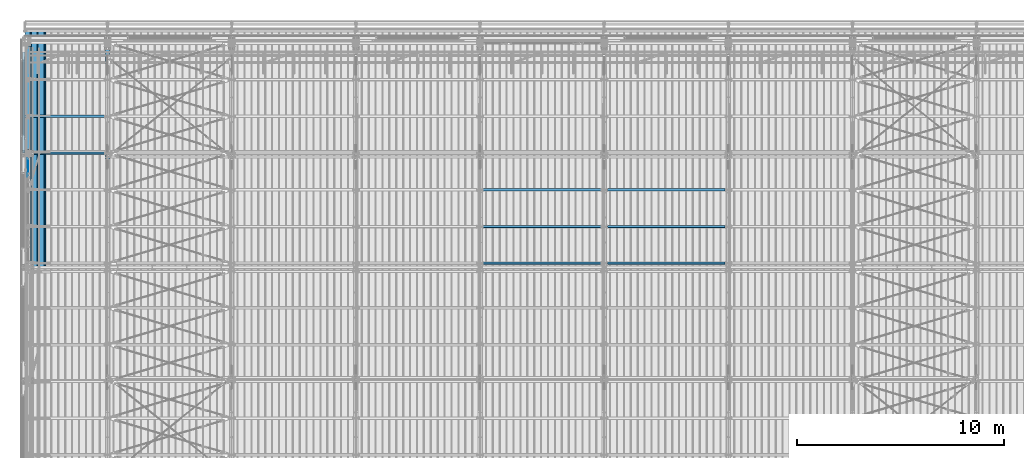
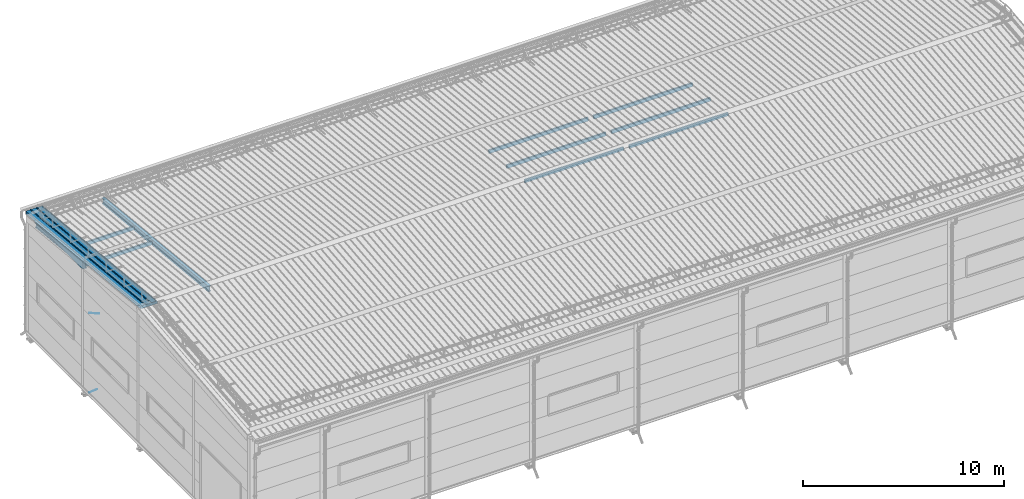
# One storey, part 262 of 709: 12 beams, 2 members, 2 openings, 14 elements without a shape of their own.
"""IFC4 building model written with IfcOpenShell, lengths in millimetres."""

from ifc_helpers import new_model, si_unit, direction, frame, origin_with_axes, place, context, subcontext, project, spatial, line, indexed_curve, outline, extrude, polygons, material, element, aggregate, save


model = new_model("IFC4")

# Units and contexts
model_context = context("Model", 3, precision=0.2, world=origin_with_axes(), true_north=direction((0.0, 1.0)))
body_context = subcontext(model_context, "Body", "Model", "MODEL_VIEW")
reference_context = subcontext(model_context, "Reference", "Model", "MODEL_VIEW")
ifc_project = project(units=[si_unit("LENGTHUNIT", "METRE", prefix="MILLI"), si_unit("AREAUNIT", "SQUARE_METRE"), si_unit("VOLUMEUNIT", "CUBIC_METRE"), si_unit("MASSUNIT", "GRAM", prefix="KILO"), si_unit("TIMEUNIT", "SECOND"), si_unit("PLANEANGLEUNIT", "RADIAN"), si_unit("SOLIDANGLEUNIT", "STERADIAN"), si_unit("THERMODYNAMICTEMPERATUREUNIT", "DEGREE_CELSIUS"), si_unit("LUMINOUSINTENSITYUNIT", "LUMEN")], contexts=[model_context])

# Site, building, storey
site_placement = place(None, origin_with_axes())
site = spatial("IfcSite", under=ifc_project, at=site_placement, CompositionType="ELEMENT")
building_placement = place(site_placement, origin_with_axes())
building = spatial("IfcBuilding", under=site, at=building_placement, Name="Undefined", CompositionType="ELEMENT")
storey_placement = place(building_placement, origin_with_axes())
storey = spatial("IfcBuildingStorey", under=building, at=storey_placement, Name="Undefined", CompositionType="ELEMENT", Elevation=0.0)

# Assembly, beam
assembly_1_placement = place(storey_placement, frame((4000.0, 21654.0, 7089.70002), z_axis=(-1.0, 0.0, 0.0), x_axis=(0.0, -0.9950371902, 0.099503719)))
assembly_1 = element("IfcElementAssembly", 1, at=assembly_1_placement, inside=storey)
ifc_material_1 = material(Name="C355-5", Category="STEEL")
beam_1_placement = place(assembly_1_placement, origin_with_axes())
beam_1 = element("IfcBeam", 2, at=beam_1_placement, material=ifc_material_1, ObjectType="432", context=body_context, shape_type="Tessellation", body=[
    polygons([(3.80474, -173.0, -87.0), (4.70474, -164.0, -87.0), (10665.6128, -164.0, -87.0), (10664.7128, -173.0, -87.0), (4.70474, -164.0, -3.0), (10665.6128, -164.0, -3.0), (37.50474, 164.0, -3.0), (10698.4128, 164.0, -3.0), (37.50474, 164.0, -87.0), (10698.4128, 164.0, -87.0), (38.40474, 173.0, -87.0), (10699.3128, 173.0, -87.0), (38.40474, 173.0, 87.0), (10699.3128, 173.0, 87.0), (37.50474, 164.0, 87.0), (10698.4128, 164.0, 87.0), (37.50474, 164.0, 3.0), (10698.4128, 164.0, 3.0), (4.70474, -164.0, 3.0), (10665.6128, -164.0, 3.0), (4.70474, -164.0, 87.0), (10665.6128, -164.0, 87.0), (3.80474, -173.0, 87.0), (10664.7128, -173.0, 87.0)], [[[1, 2, 3, 4]], [[2, 5, 6, 3]], [[5, 7, 8, 6]], [[7, 9, 10, 8]], [[9, 11, 12, 10]], [[11, 13, 14, 12]], [[13, 15, 16, 14]], [[15, 17, 18, 16]], [[17, 19, 20, 18]], [[19, 21, 22, 20]], [[21, 23, 24, 22]], [[23, 1, 4, 24]], [[6, 8, 10, 12, 14, 16, 18, 20, 22, 24, 4, 3]], [[23, 21, 19, 17, 15, 13, 11, 9, 7, 5, 2, 1]]], closed=True),
])
aggregate(assembly_1, [beam_1])

assembly_2_placement = place(storey_placement, frame((162.5, 21654.0, 6929.907), z_axis=(-1.0, 0.0, 0.0), x_axis=(0.0, -0.9950371902, 0.099503719)))
assembly_2 = element("IfcElementAssembly", 3, at=assembly_2_placement, inside=storey)
ifc_material_2 = material(Name="C255-4", Category="STEEL")
beam_2_placement = place(assembly_2_placement, origin_with_axes())
beam_2 = element("IfcBeam", 4, at=beam_2_placement, material=ifc_material_2, ObjectType="451", context=body_context, shape_type="Tessellation", body=[
    polygons([(-15.12818, -124.0, 62.0), (-15.12818, -116.0, 62.0), (-15.12818, -116.0, 2.5), (-15.12818, 116.0, 2.5), (-15.12818, 116.0, 62.0), (-15.12818, 124.0, 62.0), (-15.12818, 124.0, -62.0), (-15.12818, 116.0, -62.0), (-15.12818, 116.0, -2.5), (-15.12818, -116.0, -2.5), (-15.12818, -116.0, -62.0), (-15.12818, -124.0, -62.0), (4996.83432, 124.0, 62.0), (4996.83432, 124.0, -62.0), (4996.83432, 116.0, -62.0), (4996.83432, 116.0, -2.5), (4996.83432, -116.0, -2.5), (4996.83432, -116.0, -62.0), (4996.83432, -124.0, -62.0), (4996.83432, -124.0, 62.0), (4996.83432, -116.0, 62.0), (4996.83432, -116.0, 2.5), (4996.83432, 116.0, 2.5), (4996.83432, 116.0, 62.0)], [[[1, 2, 3, 4, 5, 6, 7, 8, 9, 10, 11, 12]], [[7, 6, 13, 14]], [[8, 7, 14, 15]], [[9, 8, 15, 16]], [[10, 9, 16, 17]], [[11, 10, 17, 18]], [[12, 11, 18, 19]], [[1, 12, 19, 20]], [[2, 1, 20, 21]], [[3, 2, 21, 22]], [[4, 3, 22, 23]], [[5, 4, 23, 24]], [[6, 5, 24, 13]], [[23, 22, 21, 20, 19, 18, 17, 16, 15, 14, 13, 24]]], closed=True),
])
aggregate(assembly_2, [beam_2])

# Assembly, member, voiding feature
assembly_3_placement = place(storey_placement, frame((165.0, 16500.0, -155.0), z_axis=(-1.0, 0.0, 0.0), x_axis=(0.0, -0.7603239329, 0.649544084)))
assembly_3 = element("IfcElementAssembly", 5, at=assembly_3_placement, inside=storey)
member_1_placement = place(assembly_3_placement, origin_with_axes())
member_1 = element("IfcMember", 6, at=member_1_placement, material=ifc_material_1, ObjectType="513", context=body_context, shape_type="Tessellation", body=[
    polygons([(1390.0, 7.36122, 4.25), (1390.0, 6.01041, 6.01041), (1390.0, 4.25, 7.36122), (1390.0, 2.19996, 8.21037), (1390.0, 0.0, 8.5), (1390.0, -2.19996, 8.21037), (1390.0, -4.25, 7.36122), (1390.0, -6.01041, 6.01041), (1390.0, -7.36122, 4.25), (1390.0, -8.21037, 2.19996), (1390.0, -8.5, 0.0), (1390.0, -8.21037, -2.19996), (1390.0, -7.36122, -4.25), (1390.0, -6.01041, -6.01041), (1390.0, -4.25, -7.36122), (1390.0, -2.19996, -8.21037), (1390.0, 0.0, -8.5), (1390.0, 2.19996, -8.21037), (1390.0, 4.25, -7.36122), (1390.0, 6.01041, -6.01041), (1390.0, 7.36122, -4.25), (1390.0, 8.21037, -2.19996), (1390.0, 8.5, 0.0), (1390.0, 8.21037, 2.19996), (1210.0, 8.21037, 2.19996), (1210.0, 7.36122, 4.25), (1210.0, 6.01041, 6.01041), (1210.0, 4.25, 7.36122), (1210.0, 2.19996, 8.21037), (1210.0, 0.0, 8.5), (1210.0, -2.19996, 8.21037), (1210.0, -4.25, 7.36122), (1210.0, -6.01041, 6.01041), (1210.0, -7.36122, 4.25), (1210.0, -8.21037, 2.19996), (1210.0, -8.5, 0.0), (1210.0, -8.21037, -2.19996), (1210.0, -7.36122, -4.25), (1210.0, -6.01041, -6.01041), (1210.0, -4.25, -7.36122), (1210.0, -2.19996, -8.21037), (1210.0, 0.0, -8.5), (1210.0, 2.19996, -8.21037), (1210.0, 4.25, -7.36122), (1210.0, 6.01041, -6.01041), (1210.0, 7.36122, -4.25), (1210.0, 8.21037, -2.19996), (1210.0, 8.5, 0.0), (1210.0, 10.0, 0.0), (1210.0, 9.65926, 2.58819), (1210.0, 8.66025, 5.0), (1210.0, 7.07107, 7.07107), (1210.0, 5.0, 8.66025), (1210.0, 2.58819, 9.65926), (1210.0, 0.0, 10.0), (1210.0, -2.58819, 9.65926), (1210.0, -5.0, 8.66025), (1210.0, -7.07107, 7.07107), (1210.0, -8.66025, 5.0), (1210.0, -9.65926, 2.58819), (1210.0, -10.0, 0.0), (1210.0, -9.65926, -2.58819), (1210.0, -8.66025, -5.0), (1210.0, -7.07107, -7.07107), (1210.0, -5.0, -8.66025), (1210.0, -2.58819, -9.65926), (1210.0, 0.0, -10.0), (1210.0, 2.58819, -9.65926), (1210.0, 5.0, -8.66025), (1210.0, 7.07107, -7.07107), (1210.0, 8.66025, -5.0), (1210.0, 9.65926, -2.58819), (179.82193, 2.58819, 9.65926), (179.82193, 5.0, 8.66025), (179.82193, 7.07107, 7.07107), (179.82193, 8.66025, 5.0), (179.82193, 9.65926, 2.58819), (179.82193, 10.0, 0.0), (179.82193, 9.65926, -2.58819), (179.82193, 8.66025, -5.0), (179.82193, 7.07107, -7.07107), (179.82193, 5.0, -8.66025), (179.82193, 2.58819, -9.65926), (179.82193, 0.0, -10.0), (179.82193, -2.58819, -9.65926), (179.82193, -5.0, -8.66025), (179.82193, -7.07107, -7.07107), (179.82193, -8.66025, -5.0), (179.82193, -9.65926, -2.58819), (179.82193, -10.0, 0.0), (179.82193, -9.65926, 2.58819), (179.82193, -8.66025, 5.0), (179.82193, -7.07107, 7.07107), (179.82193, -5.0, 8.66025), (179.82193, -2.58819, 9.65926), (179.82193, 0.0, 10.0)], [[[1, 2, 3, 4, 5, 6, 7, 8, 9, 10, 11, 12, 13, 14, 15, 16, 17, 18, 19, 20, 21, 22, 23, 24]], [[24, 25, 26, 1]], [[1, 26, 27, 2]], [[2, 27, 28, 3]], [[3, 28, 29, 4]], [[4, 29, 30, 5]], [[5, 30, 31, 6]], [[6, 31, 32, 7]], [[7, 32, 33, 8]], [[8, 33, 34, 9]], [[9, 34, 35, 10]], [[10, 35, 36, 11]], [[11, 36, 37, 12]], [[12, 37, 38, 13]], [[13, 38, 39, 14]], [[14, 39, 40, 15]], [[15, 40, 41, 16]], [[16, 41, 42, 17]], [[17, 42, 43, 18]], [[18, 43, 44, 19]], [[19, 44, 45, 20]], [[20, 45, 46, 21]], [[21, 46, 47, 22]], [[22, 47, 48, 23]], [[23, 48, 25, 24]], [[49, 50, 51, 52, 53, 54, 55, 56, 57, 58, 59, 60, 61, 62, 63, 64, 65, 66, 67, 68, 69, 70, 71, 72], [47, 46, 45, 44, 43, 42, 41, 40, 39, 38, 37, 36, 35, 34, 33, 32, 31, 30, 29, 28, 27, 26, 25, 48]], [[73, 74, 75, 76, 77, 78, 79, 80, 81, 82, 83, 84, 85, 86, 87, 88, 89, 90, 91, 92, 93, 94, 95, 96]], [[79, 78, 49, 72]], [[80, 79, 72, 71]], [[81, 80, 71, 70]], [[82, 81, 70, 69]], [[83, 82, 69, 68]], [[84, 83, 68, 67]], [[85, 84, 67, 66]], [[86, 85, 66, 65]], [[87, 86, 65, 64]], [[88, 87, 64, 63]], [[89, 88, 63, 62]], [[90, 89, 62, 61]], [[91, 90, 61, 60]], [[92, 91, 60, 59]], [[93, 92, 59, 58]], [[94, 93, 58, 57]], [[95, 94, 57, 56]], [[96, 95, 56, 55]], [[73, 96, 55, 54]], [[74, 73, 54, 53]], [[75, 74, 53, 52]], [[76, 75, 52, 51]], [[77, 76, 51, 50]], [[78, 77, 50, 49]]], closed=True),
])
voiding_feature_1_placement = place(member_1_placement, frame((1390.0, 0.0, 0.0), z_axis=(0.0, 1.0, 0.0), x_axis=(-1.0, 0.0, 0.0)))
element("IfcVoidingFeature", 7, at=voiding_feature_1_placement, cuts=member_1, PredefinedType="HOLE", context=reference_context, identifier="Reference", shape_type="SolidModel", body=[
    extrude(outline(indexed_curve([(10.5, 0.0), (10.14222, 2.7176), (9.09327, 5.25), (7.42462, 7.42462), (5.25, 9.09327), (2.7176, 10.14222), (0.0, 10.5), (-2.7176, 10.14222), (-5.25, 9.09327), (-7.42462, 7.42462), (-9.09327, 5.25), (-10.14222, 2.7176), (-10.5, 0.0), (-10.14222, -2.7176), (-9.09327, -5.25), (-7.42462, -7.42462), (-5.25, -9.09327), (-2.7176, -10.14222), (0.0, -10.5), (2.7176, -10.14222), (5.25, -9.09327), (7.42462, -7.42462), (9.09327, -5.25), (10.14222, -2.7176)], segments=[line(1, 2, 3, 4, 5, 6, 7, 8, 9, 10, 11, 12, 13, 14, 15, 16, 17, 18, 19, 20, 21, 22, 23, 24, 1)])), frame((0.0, 0.0, 0.0), z_axis=(-1.0, 0.0, 0.0), x_axis=(0.0, 0.0, 1.0)), (0.0, 0.0, -1.0), 180.0),
])
aggregate(assembly_3, [member_1])

assembly_4_placement = place(storey_placement, frame((165.0, 16425.5, 4740.0), z_axis=(-1.0, 0.0, 0.0), x_axis=(0.0, -0.866144648, 0.499793406)))
assembly_4 = element("IfcElementAssembly", 8, at=assembly_4_placement, inside=storey)
member_2_placement = place(assembly_4_placement, origin_with_axes())
member_2 = element("IfcMember", 9, at=member_2_placement, material=ifc_material_1, ObjectType="515", context=body_context, shape_type="Tessellation", body=[
    polygons([(1390.0, 7.36122, 4.25), (1390.0, 6.01041, 6.01041), (1390.0, 4.25, 7.36122), (1390.0, 2.19996, 8.21037), (1390.0, 0.0, 8.5), (1390.0, -2.19996, 8.21037), (1390.0, -4.25, 7.36122), (1390.0, -6.01041, 6.01041), (1390.0, -7.36122, 4.25), (1390.0, -8.21037, 2.19996), (1390.0, -8.5, 0.0), (1390.0, -8.21037, -2.19996), (1390.0, -7.36122, -4.25), (1390.0, -6.01041, -6.01041), (1390.0, -4.25, -7.36122), (1390.0, -2.19996, -8.21037), (1390.0, 0.0, -8.5), (1390.0, 2.19996, -8.21037), (1390.0, 4.25, -7.36122), (1390.0, 6.01041, -6.01041), (1390.0, 7.36122, -4.25), (1390.0, 8.21037, -2.19996), (1390.0, 8.5, 0.0), (1390.0, 8.21037, 2.19996), (1210.0, 8.21037, 2.19996), (1210.0, 7.36122, 4.25), (1210.0, 6.01041, 6.01041), (1210.0, 4.25, 7.36122), (1210.0, 2.19996, 8.21037), (1210.0, 0.0, 8.5), (1210.0, -2.19996, 8.21037), (1210.0, -4.25, 7.36122), (1210.0, -6.01041, 6.01041), (1210.0, -7.36122, 4.25), (1210.0, -8.21037, 2.19996), (1210.0, -8.5, 0.0), (1210.0, -8.21037, -2.19996), (1210.0, -7.36122, -4.25), (1210.0, -6.01041, -6.01041), (1210.0, -4.25, -7.36122), (1210.0, -2.19996, -8.21037), (1210.0, 0.0, -8.5), (1210.0, 2.19996, -8.21037), (1210.0, 4.25, -7.36122), (1210.0, 6.01041, -6.01041), (1210.0, 7.36122, -4.25), (1210.0, 8.21037, -2.19996), (1210.0, 8.5, 0.0), (1210.0, 10.0, 0.0), (1210.0, 9.65926, 2.58819), (1210.0, 8.66025, 5.0), (1210.0, 7.07107, 7.07107), (1210.0, 5.0, 8.66025), (1210.0, 2.58819, 9.65926), (1210.0, 0.0, 10.0), (1210.0, -2.58819, 9.65926), (1210.0, -5.0, 8.66025), (1210.0, -7.07107, 7.07107), (1210.0, -8.66025, 5.0), (1210.0, -9.65926, 2.58819), (1210.0, -10.0, 0.0), (1210.0, -9.65926, -2.58819), (1210.0, -8.66025, -5.0), (1210.0, -7.07107, -7.07107), (1210.0, -5.0, -8.66025), (1210.0, -2.58819, -9.65926), (1210.0, 0.0, -10.0), (1210.0, 2.58819, -9.65926), (1210.0, 5.0, -8.66025), (1210.0, 7.07107, -7.07107), (1210.0, 8.66025, -5.0), (1210.0, 9.65926, -2.58819), (70.0, 2.58819, 9.65926), (70.0, 5.0, 8.66025), (70.0, 7.07107, 7.07107), (70.0, 8.66025, 5.0), (70.0, 9.65926, 2.58819), (70.0, 10.0, 0.0), (70.0, 9.65926, -2.58819), (70.0, 8.66025, -5.0), (70.0, 7.07107, -7.07107), (70.0, 5.0, -8.66025), (70.0, 2.58819, -9.65926), (70.0, 0.0, -10.0), (70.0, -2.58819, -9.65926), (70.0, -5.0, -8.66025), (70.0, -7.07107, -7.07107), (70.0, -8.66025, -5.0), (70.0, -9.65926, -2.58819), (70.0, -10.0, 0.0), (70.0, -9.65926, 2.58819), (70.0, -8.66025, 5.0), (70.0, -7.07107, 7.07107), (70.0, -5.0, 8.66025), (70.0, -2.58819, 9.65926), (70.0, 0.0, 10.0)], [[[1, 2, 3, 4, 5, 6, 7, 8, 9, 10, 11, 12, 13, 14, 15, 16, 17, 18, 19, 20, 21, 22, 23, 24]], [[24, 25, 26, 1]], [[1, 26, 27, 2]], [[2, 27, 28, 3]], [[3, 28, 29, 4]], [[4, 29, 30, 5]], [[5, 30, 31, 6]], [[6, 31, 32, 7]], [[7, 32, 33, 8]], [[8, 33, 34, 9]], [[9, 34, 35, 10]], [[10, 35, 36, 11]], [[11, 36, 37, 12]], [[12, 37, 38, 13]], [[13, 38, 39, 14]], [[14, 39, 40, 15]], [[15, 40, 41, 16]], [[16, 41, 42, 17]], [[17, 42, 43, 18]], [[18, 43, 44, 19]], [[19, 44, 45, 20]], [[20, 45, 46, 21]], [[21, 46, 47, 22]], [[22, 47, 48, 23]], [[23, 48, 25, 24]], [[49, 50, 51, 52, 53, 54, 55, 56, 57, 58, 59, 60, 61, 62, 63, 64, 65, 66, 67, 68, 69, 70, 71, 72], [47, 46, 45, 44, 43, 42, 41, 40, 39, 38, 37, 36, 35, 34, 33, 32, 31, 30, 29, 28, 27, 26, 25, 48]], [[73, 74, 75, 76, 77, 78, 79, 80, 81, 82, 83, 84, 85, 86, 87, 88, 89, 90, 91, 92, 93, 94, 95, 96]], [[79, 78, 49, 72]], [[80, 79, 72, 71]], [[81, 80, 71, 70]], [[82, 81, 70, 69]], [[83, 82, 69, 68]], [[84, 83, 68, 67]], [[85, 84, 67, 66]], [[86, 85, 66, 65]], [[87, 86, 65, 64]], [[88, 87, 64, 63]], [[89, 88, 63, 62]], [[90, 89, 62, 61]], [[91, 90, 61, 60]], [[92, 91, 60, 59]], [[93, 92, 59, 58]], [[94, 93, 58, 57]], [[95, 94, 57, 56]], [[96, 95, 56, 55]], [[73, 96, 55, 54]], [[74, 73, 54, 53]], [[75, 74, 53, 52]], [[76, 75, 52, 51]], [[77, 76, 51, 50]], [[78, 77, 50, 49]]], closed=True),
])
voiding_feature_2_placement = place(member_2_placement, frame((1390.0, 0.0, 0.0), z_axis=(0.0, 1.0, 0.0), x_axis=(-1.0, 0.0, 0.0)))
element("IfcVoidingFeature", 10, at=voiding_feature_2_placement, cuts=member_2, PredefinedType="HOLE", context=reference_context, identifier="Reference", shape_type="SolidModel", body=[
    extrude(outline(indexed_curve([(10.5, 0.0), (10.14222, 2.7176), (9.09327, 5.25), (7.42462, 7.42462), (5.25, 9.09327), (2.7176, 10.14222), (0.0, 10.5), (-2.7176, 10.14222), (-5.25, 9.09327), (-7.42462, 7.42462), (-9.09327, 5.25), (-10.14222, 2.7176), (-10.5, 0.0), (-10.14222, -2.7176), (-9.09327, -5.25), (-7.42462, -7.42462), (-5.25, -9.09327), (-2.7176, -10.14222), (0.0, -10.5), (2.7176, -10.14222), (5.25, -9.09327), (7.42462, -7.42462), (9.09327, -5.25), (10.14222, -2.7176)], segments=[line(1, 2, 3, 4, 5, 6, 7, 8, 9, 10, 11, 12, 13, 14, 15, 16, 17, 18, 19, 20, 21, 22, 23, 24, 1)])), frame((0.0, 0.0, 0.0), z_axis=(-1.0, 0.0, 0.0), x_axis=(0.0, 0.0, 1.0)), (0.0, 0.0, -1.0), 180.0),
])
aggregate(assembly_4, [member_2])

# Assembly, beam
assembly_5_placement = place(storey_placement, frame((4000.0, 16509.95037, 7677.42918), z_axis=(0.0, -0.9950371902, 0.099503719), x_axis=(-1.0, 0.0, 0.0)))
assembly_5 = element("IfcElementAssembly", 11, at=assembly_5_placement, inside=storey)
ifc_material_3 = material(Name="C355", Category="STEEL")
beam_3_placement = place(assembly_5_placement, origin_with_axes())
beam_3 = element("IfcBeam", 12, at=beam_3_placement, material=ifc_material_3, ObjectType="564", context=body_context, shape_type="Tessellation", body=[
    polygons([(155.0, -100.0, 50.0), (155.0, -100.0, -50.0), (3972.0, -100.0, -50.0), (3972.0, -100.0, 50.0), (155.0, 100.0, 50.0), (3972.0, 100.0, 50.0), (155.0, 100.0, -50.0), (3972.0, 100.0, -50.0), (155.0, -96.0, 46.0), (155.0, 96.0, 46.0), (3972.0, 96.0, 46.0), (3972.0, -96.0, 46.0), (155.0, -96.0, -46.0), (3972.0, -96.0, -46.0), (155.0, 96.0, -46.0), (3972.0, 96.0, -46.0)], [[[1, 2, 3, 4]], [[5, 1, 4, 6]], [[7, 5, 6, 8]], [[2, 7, 8, 3]], [[1, 5, 7, 2], [15, 10, 9, 13]], [[9, 10, 11, 12]], [[13, 9, 12, 14]], [[15, 13, 14, 16]], [[10, 15, 16, 11]], [[3, 8, 6, 4], [14, 12, 11, 16]]], closed=True),
])
aggregate(assembly_5, [beam_3])

assembly_6_placement = place(storey_placement, frame((4000.0, 18286.65012, 7499.7592), z_axis=(0.0, -0.9950371902, 0.099503719), x_axis=(-1.0, 0.0, 0.0)))
assembly_6 = element("IfcElementAssembly", 13, at=assembly_6_placement, inside=storey)
beam_4_placement = place(assembly_6_placement, origin_with_axes())
beam_4 = element("IfcBeam", 14, at=beam_4_placement, material=ifc_material_3, ObjectType="563", context=body_context, shape_type="Tessellation", body=[
    polygons([(155.0, -100.0, 50.0), (155.0, -100.0, -50.0), (3992.0, -100.0, -50.0), (3992.0, -100.0, 50.0), (155.0, 100.0, 50.0), (3992.0, 100.0, 50.0), (155.0, 100.0, -50.0), (3992.0, 100.0, -50.0), (155.0, -96.0, 46.0), (155.0, 96.0, 46.0), (3992.0, 96.0, 46.0), (3992.0, -96.0, 46.0), (155.0, -96.0, -46.0), (3992.0, -96.0, -46.0), (155.0, 96.0, -46.0), (3992.0, 96.0, -46.0)], [[[1, 2, 3, 4]], [[5, 1, 4, 6]], [[7, 5, 6, 8]], [[2, 7, 8, 3]], [[1, 5, 7, 2], [15, 10, 9, 13]], [[9, 10, 11, 12]], [[13, 9, 12, 14]], [[15, 13, 14, 16]], [[10, 15, 16, 11]], [[3, 8, 6, 4], [14, 12, 11, 16]]], closed=True),
])
aggregate(assembly_6, [beam_4])

assembly_7_placement = place(storey_placement, frame((28000.0, 11191.04467, 8219.40952), z_axis=(0.0, -0.9950371902, 0.099503719), x_axis=(-1.0, 0.0, 0.0)))
assembly_7 = element("IfcElementAssembly", 15, at=assembly_7_placement, inside=storey)
beam_5_placement = place(assembly_7_placement, origin_with_axes())
beam_5 = element("IfcBeam", 16, at=beam_5_placement, material=ifc_material_3, ObjectType="580", context=body_context, shape_type="Tessellation", body=[
    polygons([(155.0, -86.0, -46.0), (155.0, -86.0, 46.0), (5845.0, -86.0, 46.0), (5845.0, -86.0, -46.0), (155.0, 86.0, 46.0), (5845.0, 86.0, 46.0), (155.0, 86.0, -46.0), (5845.0, 86.0, -46.0), (155.0, -90.0, -50.0), (155.0, 90.0, -50.0), (5845.0, 90.0, -50.0), (5845.0, -90.0, -50.0), (155.0, 90.0, 50.0), (5845.0, 90.0, 50.0), (155.0, -90.0, 50.0), (5845.0, -90.0, 50.0)], [[[1, 2, 3, 4]], [[2, 5, 6, 3]], [[5, 7, 8, 6]], [[7, 1, 4, 8]], [[9, 10, 11, 12]], [[10, 13, 14, 11]], [[13, 15, 16, 14]], [[15, 9, 12, 16]], [[14, 16, 12, 11], [6, 8, 4, 3]], [[15, 13, 10, 9], [7, 5, 2, 1]]], closed=True),
])
aggregate(assembly_7, [beam_5])

assembly_8_placement = place(storey_placement, frame((28000.0, 12963.34988, 8032.12913), z_axis=(0.0, -0.9950371902, 0.099503719), x_axis=(-1.0, 0.0, 0.0)))
assembly_8 = element("IfcElementAssembly", 17, at=assembly_8_placement, inside=storey)
beam_6_placement = place(assembly_8_placement, origin_with_axes())
beam_6 = element("IfcBeam", 18, at=beam_6_placement, material=ifc_material_3, ObjectType="579", context=body_context, shape_type="Tessellation", body=[
    polygons([(155.0, -96.0, -46.0), (155.0, -96.0, 46.0), (5845.0, -96.0, 46.0), (5845.0, -96.0, -46.0), (155.0, 96.0, 46.0), (5845.0, 96.0, 46.0), (155.0, 96.0, -46.0), (5845.0, 96.0, -46.0), (155.0, -100.0, -50.0), (155.0, 100.0, -50.0), (5845.0, 100.0, -50.0), (5845.0, -100.0, -50.0), (155.0, 100.0, 50.0), (5845.0, 100.0, 50.0), (155.0, -100.0, 50.0), (5845.0, -100.0, 50.0)], [[[1, 2, 3, 4]], [[2, 5, 6, 3]], [[5, 7, 8, 6]], [[7, 1, 4, 8]], [[9, 10, 11, 12]], [[10, 13, 14, 11]], [[13, 15, 16, 14]], [[15, 9, 12, 16]], [[14, 16, 12, 11], [6, 8, 4, 3]], [[15, 13, 10, 9], [7, 5, 2, 1]]], closed=True),
])
aggregate(assembly_8, [beam_6])

assembly_9_placement = place(storey_placement, frame((28000.0, 14736.65012, 7854.7991), z_axis=(0.0, -0.9950371902, 0.099503719), x_axis=(-1.0, 0.0, 0.0)))
assembly_9 = element("IfcElementAssembly", 19, at=assembly_9_placement, inside=storey)
beam_7_placement = place(assembly_9_placement, origin_with_axes())
beam_7 = element("IfcBeam", 20, at=beam_7_placement, material=ifc_material_3, ObjectType="579", context=body_context, shape_type="Tessellation", body=[
    polygons([(155.0, -96.0, -46.0), (155.0, -96.0, 46.0), (5845.0, -96.0, 46.0), (5845.0, -96.0, -46.0), (155.0, 96.0, 46.0), (5845.0, 96.0, 46.0), (155.0, 96.0, -46.0), (5845.0, 96.0, -46.0), (155.0, -100.0, -50.0), (155.0, 100.0, -50.0), (5845.0, 100.0, -50.0), (5845.0, -100.0, -50.0), (155.0, 100.0, 50.0), (5845.0, 100.0, 50.0), (155.0, -100.0, 50.0), (5845.0, -100.0, 50.0)], [[[1, 2, 3, 4]], [[2, 5, 6, 3]], [[5, 7, 8, 6]], [[7, 1, 4, 8]], [[9, 10, 11, 12]], [[10, 13, 14, 11]], [[13, 15, 16, 14]], [[15, 9, 12, 16]], [[14, 16, 12, 11], [6, 8, 4, 3]], [[15, 13, 10, 9], [7, 5, 2, 1]]], closed=True),
])
aggregate(assembly_9, [beam_7])

assembly_10_placement = place(storey_placement, frame((34000.0, 11191.04467, 8219.40952), z_axis=(0.0, -0.9950371902, 0.099503719), x_axis=(-1.0, 0.0, 0.0)))
assembly_10 = element("IfcElementAssembly", 21, at=assembly_10_placement, inside=storey)
beam_8_placement = place(assembly_10_placement, origin_with_axes())
beam_8 = element("IfcBeam", 22, at=beam_8_placement, material=ifc_material_3, ObjectType="580", context=body_context, shape_type="Tessellation", body=[
    polygons([(155.0, -86.0, -46.0), (155.0, -86.0, 46.0), (5845.0, -86.0, 46.0), (5845.0, -86.0, -46.0), (155.0, 86.0, 46.0), (5845.0, 86.0, 46.0), (155.0, 86.0, -46.0), (5845.0, 86.0, -46.0), (155.0, -90.0, -50.0), (155.0, 90.0, -50.0), (5845.0, 90.0, -50.0), (5845.0, -90.0, -50.0), (155.0, 90.0, 50.0), (5845.0, 90.0, 50.0), (155.0, -90.0, 50.0), (5845.0, -90.0, 50.0)], [[[1, 2, 3, 4]], [[2, 5, 6, 3]], [[5, 7, 8, 6]], [[7, 1, 4, 8]], [[9, 10, 11, 12]], [[10, 13, 14, 11]], [[13, 15, 16, 14]], [[15, 9, 12, 16]], [[14, 16, 12, 11], [6, 8, 4, 3]], [[15, 13, 10, 9], [7, 5, 2, 1]]], closed=True),
])
aggregate(assembly_10, [beam_8])

assembly_11_placement = place(storey_placement, frame((34000.0, 12963.34988, 8032.12913), z_axis=(0.0, -0.9950371902, 0.099503719), x_axis=(-1.0, 0.0, 0.0)))
assembly_11 = element("IfcElementAssembly", 23, at=assembly_11_placement, inside=storey)
beam_9_placement = place(assembly_11_placement, origin_with_axes())
beam_9 = element("IfcBeam", 24, at=beam_9_placement, material=ifc_material_3, ObjectType="579", context=body_context, shape_type="Tessellation", body=[
    polygons([(155.0, -96.0, -46.0), (155.0, -96.0, 46.0), (5845.0, -96.0, 46.0), (5845.0, -96.0, -46.0), (155.0, 96.0, 46.0), (5845.0, 96.0, 46.0), (155.0, 96.0, -46.0), (5845.0, 96.0, -46.0), (155.0, -100.0, -50.0), (155.0, 100.0, -50.0), (5845.0, 100.0, -50.0), (5845.0, -100.0, -50.0), (155.0, 100.0, 50.0), (5845.0, 100.0, 50.0), (155.0, -100.0, 50.0), (5845.0, -100.0, 50.0)], [[[1, 2, 3, 4]], [[2, 5, 6, 3]], [[5, 7, 8, 6]], [[7, 1, 4, 8]], [[9, 10, 11, 12]], [[10, 13, 14, 11]], [[13, 15, 16, 14]], [[15, 9, 12, 16]], [[14, 16, 12, 11], [6, 8, 4, 3]], [[15, 13, 10, 9], [7, 5, 2, 1]]], closed=True),
])
aggregate(assembly_11, [beam_9])

assembly_12_placement = place(storey_placement, frame((34000.0, 14736.65012, 7854.7991), z_axis=(0.0, -0.9950371902, 0.099503719), x_axis=(-1.0, 0.0, 0.0)))
assembly_12 = element("IfcElementAssembly", 25, at=assembly_12_placement, inside=storey)
beam_10_placement = place(assembly_12_placement, origin_with_axes())
beam_10 = element("IfcBeam", 26, at=beam_10_placement, material=ifc_material_3, ObjectType="579", context=body_context, shape_type="Tessellation", body=[
    polygons([(155.0, -96.0, -46.0), (155.0, -96.0, 46.0), (5845.0, -96.0, 46.0), (5845.0, -96.0, -46.0), (155.0, 96.0, 46.0), (5845.0, 96.0, 46.0), (155.0, 96.0, -46.0), (5845.0, 96.0, -46.0), (155.0, -100.0, -50.0), (155.0, 100.0, -50.0), (5845.0, 100.0, -50.0), (5845.0, -100.0, -50.0), (155.0, 100.0, 50.0), (5845.0, 100.0, 50.0), (155.0, -100.0, 50.0), (5845.0, -100.0, 50.0)], [[[1, 2, 3, 4]], [[2, 5, 6, 3]], [[5, 7, 8, 6]], [[7, 1, 4, 8]], [[9, 10, 11, 12]], [[10, 13, 14, 11]], [[13, 15, 16, 14]], [[15, 9, 12, 16]], [[14, 16, 12, 11], [6, 8, 4, 3]], [[15, 13, 10, 9], [7, 5, 2, 1]]], closed=True),
])
aggregate(assembly_12, [beam_10])

assembly_13_placement = place(storey_placement, frame((452.44, 11009.10459, 8419.96887), z_axis=(1.0, 0.0, 0.0), x_axis=(0.0, 0.9950371902, -0.099503719)))
assembly_13 = element("IfcElementAssembly", 27, at=assembly_13_placement, inside=storey)
ifc_material_4 = material(Name="Insulation", Category="Insulation")
beam_11_placement = place(assembly_13_placement, origin_with_axes())
beam_11 = element("IfcBeam", 28, at=beam_11_placement, material=ifc_material_4, ObjectType="P-100", context=body_context, shape_type="Tessellation", body=[
    polygons([(0.0, -89.5, 562.55841), (0.0, -91.5, 562.55841), (11459.0, -91.5, 562.55841), (11459.0, -89.5, 562.55841), (0.0, -89.5, 527.55841), (11459.0, -89.5, 527.55841), (0.0, 57.5, 527.55841), (11459.0, 57.5, 527.55841), (0.0, 88.5, 510.2379), (11459.0, 88.5, 510.2379), (0.0, 88.5, 489.7621), (11459.0, 88.5, 489.7621), (0.0, 58.5, 472.44159), (11459.0, 58.5, 472.44159), (0.0, 58.5, 196.71923), (11459.0, 58.5, 196.71923), (0.0, 91.5, 177.66667), (11459.0, 91.5, 177.66667), (0.0, 91.5, 155.66667), (11459.0, 91.5, 155.66667), (0.0, 58.5, 136.61411), (11459.0, 58.5, 136.61411), (0.0, 58.5, -136.61411), (11459.0, 58.5, -136.61411), (0.0, 91.5, -155.66667), (11459.0, 91.5, -155.66667), (0.0, 91.5, -177.66667), (11459.0, 91.5, -177.66667), (0.0, 58.5, -196.71923), (11459.0, 58.5, -196.71923), (11459.0, 58.5, -432.44), (0.0, 58.5, -432.44), (0.0, -91.5, -432.44), (11459.0, -91.5, -432.44)], [[[1, 2, 3, 4]], [[5, 1, 4, 6]], [[7, 5, 6, 8]], [[9, 7, 8, 10]], [[11, 9, 10, 12]], [[13, 11, 12, 14]], [[15, 13, 14, 16]], [[17, 15, 16, 18]], [[19, 17, 18, 20]], [[21, 19, 20, 22]], [[23, 21, 22, 24]], [[25, 23, 24, 26]], [[27, 25, 26, 28]], [[29, 27, 28, 30]], [[29, 30, 31, 32]], [[2, 1, 5, 7, 9, 11, 13, 15, 17, 19, 21, 23, 25, 27, 29, 32, 33]], [[3, 2, 33, 34]], [[30, 28, 26, 24, 22, 20, 18, 16, 14, 12, 10, 8, 6, 4, 3, 34, 31]], [[33, 32, 31, 34]]], closed=True),
])
aggregate(assembly_13, [beam_11])

assembly_14_placement = place(storey_placement, frame((-60.0, 16510.0, 8035.0), z_axis=(0.0, 0.0, -1.0), x_axis=(0.0, 1.0, 0.0)))
assembly_14 = element("IfcElementAssembly", 29, at=assembly_14_placement, inside=storey)
beam_12_placement = place(assembly_14_placement, origin_with_axes())
beam_12 = element("IfcBeam", 30, at=beam_12_placement, material=ifc_material_4, ObjectType="P-132", context=body_context, shape_type="Tessellation", body=[
    polygons([(0.0, 60.0, 595.0), (4886.71, 60.0, 595.0), (0.0, 60.0, 106.329), (0.0, -60.0, 595.0), (0.0, -60.0, 106.329), (4886.71, -60.0, 595.0)], [[[1, 2, 3]], [[4, 1, 3, 5]], [[4, 5, 6]], [[1, 4, 6, 2]], [[5, 3, 2, 6]]], closed=True),
])
aggregate(assembly_14, [beam_12])

save(model, "model.ifc")
